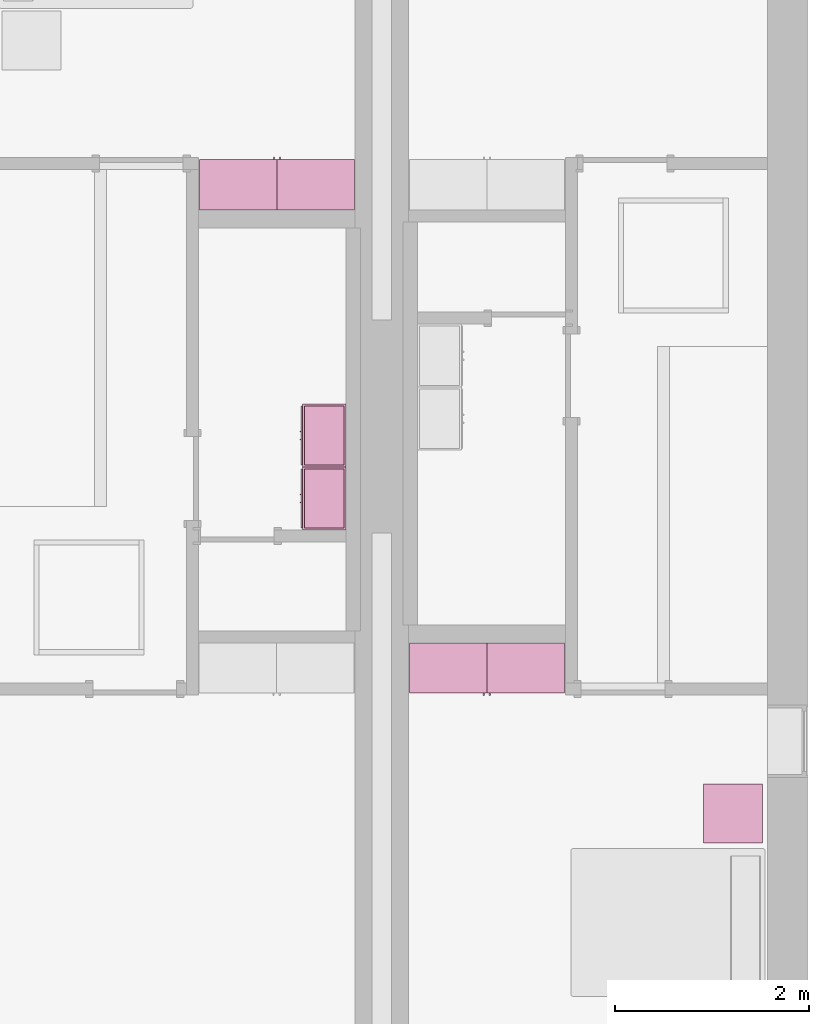
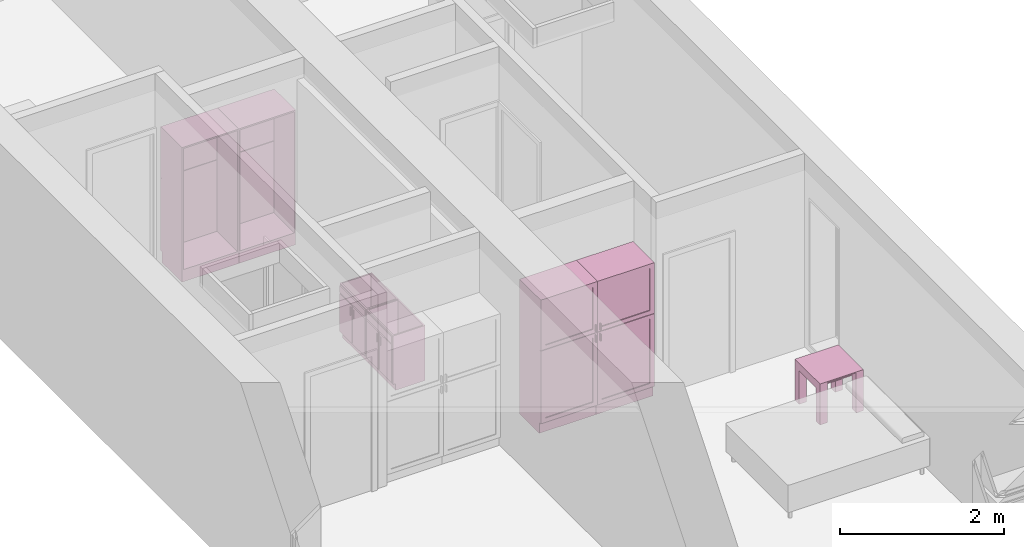
# One storey, part 8 of 10: 7 furnishings, 4 openings.
"""IFC2X3 building model written with IfcOpenShell, lengths in metres."""

from ifc_helpers import new_model, entity, si_unit, converted_unit, derived_unit, direction, frame, frame_2d, origin, origin_2d_with_axis, place, context, subcontext, project, spatial, polyline, rectangle, outline, extrude, faceted_brep, source, transform, mapped, material, material_list, type_object, type_shapes, element, save


model = new_model("IFC2X3")

# Units and contexts
model_context = context("Model", 3, precision=1e-05, world=origin(), true_north=direction((6.12303176911189e-17, 1.0)))
body_context = subcontext(model_context, "Body", "Model", "MODEL_VIEW")
ifc_project = project(units=[derived_unit("USERDEFINED", [(si_unit("LENGTHUNIT", "METRE"), -2), (si_unit("TIMEUNIT", "SECOND"), -2), (si_unit("MASSUNIT", "GRAM", prefix="KILO"), 1)]), si_unit("FREQUENCYUNIT", "HERTZ"), si_unit("LENGTHUNIT", "METRE"), si_unit("ILLUMINANCEUNIT", "LUX"), derived_unit("LINEARVELOCITYUNIT", [(si_unit("TIMEUNIT", "SECOND"), -1), (si_unit("LENGTHUNIT", "METRE"), 1)]), si_unit("POWERUNIT", "WATT"), si_unit("LUMINOUSINTENSITYUNIT", "CANDELA"), si_unit("AREAUNIT", "SQUARE_METRE"), si_unit("VOLUMEUNIT", "CUBIC_METRE"), si_unit("ELECTRICVOLTAGEUNIT", "VOLT"), si_unit("PRESSUREUNIT", "PASCAL"), converted_unit("PLANEANGLEUNIT", "DEGREE", entity("IfcRatioMeasure", 0.0174532925199433), si_unit("PLANEANGLEUNIT", "RADIAN"), dimensions=[0, 0, 0, 0, 0, 0, 0]), si_unit("THERMODYNAMICTEMPERATUREUNIT", "DEGREE_CELSIUS"), si_unit("MASSUNIT", "GRAM", prefix="KILO"), derived_unit("VOLUMETRICFLOWRATEUNIT", [(si_unit("LENGTHUNIT", "METRE"), 3), (si_unit("TIMEUNIT", "SECOND"), -1)]), si_unit("TIMEUNIT", "SECOND"), si_unit("LUMINOUSFLUXUNIT", "LUMEN"), derived_unit("USERDEFINED", [(si_unit("LUMINOUSFLUXUNIT", "LUMEN"), 1), (si_unit("TIMEUNIT", "SECOND"), 3), (si_unit("MASSUNIT", "GRAM", prefix="KILO"), -1), (si_unit("LENGTHUNIT", "METRE"), -2)]), si_unit("FORCEUNIT", "NEWTON", prefix="KILO"), si_unit("ELECTRICCURRENTUNIT", "AMPERE"), derived_unit("THERMALTRANSMITTANCEUNIT", [(si_unit("TIMEUNIT", "SECOND"), -3), (si_unit("THERMODYNAMICTEMPERATUREUNIT", "KELVIN"), -1), (si_unit("MASSUNIT", "GRAM", prefix="KILO"), 1)])], contexts=[model_context])

# Site, building, storey, space
site_placement = place(None, origin())
site = spatial("IfcSite", under=ifc_project, at=site_placement, CompositionType="ELEMENT")
building_placement = place(site_placement, origin())
building = spatial("IfcBuilding", under=site, at=building_placement, CompositionType="ELEMENT")
storey_placement = place(building_placement, frame((0.0, 0.0, 3.10000000000038)))
storey = spatial("IfcBuildingStorey", under=building, at=storey_placement, Name="Level 2", CompositionType="ELEMENT", Elevation=3.10000000000038)
space_1_placement = place(storey_placement, origin())
space_1 = spatial("IfcSpace", under=storey, at=space_1_placement, CompositionType="ELEMENT", InteriorOrExteriorSpace="INTERNAL")

# Furnishing, opening
ifc_material_1 = material(Name="Cabinets")
ifc_material_2 = material(Name="Cabinets - Handles")
ifc_material_3 = material(Name="Cabinets - Panel")
ifc_material_list_1 = material_list([ifc_material_1, ifc_material_2, ifc_material_3])
ifc_material_list_2 = material_list([ifc_material_1, ifc_material_2, ifc_material_3])
furniture_type_1 = type_object("IfcFurnitureType", Name="800 mm", AssemblyPlace="NOTDEFINED", material=ifc_material_list_2)
shared_shape_1 = source(origin(), body_context, "Body", "SweptSolid", [
    extrude(rectangle(XDim=0.00634999999999998, YDim=0.672999999999998, at=origin_2d_with_axis()), frame((0.0187377049180256, -0.504125, 0.225087499999839), z_axis=(0.0, 0.0, 1.0), x_axis=(0.0, 1.0, 0.0)), (0.0, 0.0, 1.0), 0.955960536695974),
    extrude(outline(polyline([(-0.4, -0.539892768347997), (0.4, -0.539892768347997), (0.4, 0.539892768347997), (-0.4, 0.539892768347997), (-0.4, -0.539892768347997)]), holes=[polyline([(-0.336499999999999, 0.479567768347999), (0.336499999999999, 0.479567768347999), (0.336499999999999, -0.476392768347979), (-0.336499999999999, -0.476392768347979), (-0.336499999999999, 0.479567768347999)])]), frame((0.0187377049180257, -0.52, 0.701480268347818), z_axis=(0.0, 1.0, 0.0), x_axis=(-1.0, 0.0, 0.0)), (0.0, 0.0, 1.0), 0.01905),
    extrude(rectangle(XDim=0.0254, YDim=0.0125322316306447, at=frame_2d((0.0, -3.38271077815477e-17), x_axis=(1.0, 0.0))), frame((0.387071589102702, -0.532700000000001, 1.11754803669582), z_axis=(0.0, 0.0, 1.0), x_axis=(0.0, 1.0, 0.0)), (0.0, 0.0, 1.0), 0.101599999999998),
    extrude(outline(polyline([(-0.172299999999634, 0.558941666666897), (-0.172300000000835, -1.2794708333333), (0.328649999999164, -1.27947083333363), (0.32865000000047, 0.720529166666412), (-0.156349999999529, 0.720529166666729), (-0.156349999999635, 0.558941666666897), (-0.172299999999634, 0.558941666666897)])), frame((-0.381262295081959, -0.328649999999999, 0.720529166666627), z_axis=(-1.0, 0.0, 0.0), x_axis=(0.0, 1.0, 0.0)), (0.0, 0.0, -1.0), 0.8),
    extrude(rectangle(XDim=0.0254, YDim=0.0125322316306444, at=frame_2d((0.0, 3.38271077815477e-17), x_axis=(1.0, 0.0))), frame((0.387071589102703, -0.532700000000001, 1.26994803669581), z_axis=(0.0, 0.0, 1.0), x_axis=(0.0, 1.0, 0.0)), (0.0, 0.0, 1.0), 0.1016),
    extrude(rectangle(XDim=0.00634999999999998, YDim=0.672999999999998, at=origin_2d_with_axis()), frame((0.0187377049180261, -0.504125, 1.30804803669582), z_axis=(0.0, 0.0, 1.0), x_axis=(0.0, 1.0, 0.0)), (0.0, 0.0, 1.0), 0.62845196330414),
    extrude(rectangle(XDim=0.01905, YDim=0.761899999999999, at=origin_2d_with_axis()), frame((0.018737704918025, -0.009525, 0.180637499999846), z_axis=(0.0, 0.0, 1.0), x_axis=(0.0, 1.0, 0.0)), (0.0, 0.0, 1.0), 1.80031250000011),
    extrude(outline(polyline([(-0.376138481652111, -0.4), (0.376138481652111, -0.4), (0.376138481652111, 0.4), (-0.376138481652111, 0.4), (-0.376138481652111, -0.4)]), holes=[polyline([(-0.312638481652032, -0.336499999999999), (-0.312638481652032, 0.336499999999999), (0.315813481652108, 0.336499999999999), (0.315813481652108, -0.336499999999999), (-0.312638481652032, -0.336499999999999)])]), frame((0.0187377049180258, -0.52, 1.62386151834792), z_axis=(0.0, 1.0, 0.0), x_axis=(0.0, 0.0, -1.0)), (0.0, 0.0, 1.0), 0.01905),
])
type_shapes(furniture_type_1, [shared_shape_1])
furnishing_1_placement = place(space_1_placement, frame((5.06426229508196, -11.134, 0.0)))
furnishing_1 = element("IfcFurnishingElement", 1, at=furnishing_1_placement, inside=space_1, type_object=furniture_type_1, material=ifc_material_list_1, ObjectType="800 mm", context=body_context, shape_type="MappedRepresentation", body=[
    mapped(shared_shape_1, transform((0.0, 0.0, 0.0), scale=1.0)),
])
opening_1_placement = place(storey_placement, frame((5.06426229508196, -11.134, 3.1000000000002)))
element("IfcOpeningElement", 2, at=opening_1_placement, cuts=furnishing_1, ObjectType="Opening", context=body_context, shape_type="SweptSolid", body=[
    extrude(rectangle(XDim=1.80031250000011, YDim=0.761899999999999, at=frame_2d((0.0, 0.0), x_axis=(0.0, 1.0))), frame((0.0187377049180251, 0.0, -2.01920625000048), z_axis=(0.0, -1.0, 0.0), x_axis=(-1.0, 0.0, 0.0)), (0.0, 0.0, 1.0), 0.50095),
])

ifc_material_list_3 = material_list([ifc_material_1, ifc_material_2, ifc_material_3])
ifc_material_list_4 = material_list([ifc_material_1, ifc_material_2, ifc_material_3])
furniture_type_2 = type_object("IfcFurnitureType", Name="800 mm", AssemblyPlace="NOTDEFINED", material=ifc_material_list_4)
shared_shape_2 = source(origin(), body_context, "Body", "SweptSolid", [
    extrude(outline(polyline([(-0.4, -0.539892768347997), (0.4, -0.539892768347997), (0.4, 0.539892768347997), (-0.4, 0.539892768347997), (-0.4, -0.539892768347997)]), holes=[polyline([(-0.336499999999999, 0.479567768347999), (0.336499999999999, 0.479567768347999), (0.336499999999999, -0.476392768347979), (-0.336499999999999, -0.476392768347979), (-0.336499999999999, 0.479567768347999)])]), frame((0.0187377049180257, 0.50095, 0.701480268347818), z_axis=(0.0, 1.0, 0.0), x_axis=(-1.0, 0.0, 0.0)), (0.0, 0.0, 1.0), 0.01905),
    extrude(rectangle(XDim=0.0125322316306447, YDim=0.0254, at=frame_2d((-3.38271077815477e-17, 0.0), x_axis=(1.0, 0.0))), frame((0.387071589102702, 0.532700000000001, 1.11754803669582), z_axis=(0.0, 0.0, 1.0), x_axis=(-1.0, 0.0, 0.0)), (0.0, 0.0, 1.0), 0.101599999999998),
    extrude(rectangle(XDim=0.0125322316306444, YDim=0.0254, at=frame_2d((3.38271077815477e-17, 0.0), x_axis=(1.0, 0.0))), frame((0.387071589102703, 0.532700000000001, 1.26994803669581), z_axis=(0.0, 0.0, 1.0), x_axis=(-1.0, 0.0, 0.0)), (0.0, 0.0, 1.0), 0.1016),
    extrude(outline(polyline([(-0.376138481652111, -0.4), (0.376138481652111, -0.4), (0.376138481652111, 0.4), (-0.376138481652111, 0.4), (-0.376138481652111, -0.4)]), holes=[polyline([(-0.312638481652032, -0.3365), (-0.312638481652032, 0.336499999999999), (0.315813481652108, 0.336499999999999), (0.315813481652108, -0.3365), (-0.312638481652032, -0.3365)])]), frame((0.0187377049180258, 0.50095, 1.62386151834792), z_axis=(0.0, 1.0, 0.0), x_axis=(0.0, 0.0, -1.0)), (0.0, 0.0, 1.0), 0.01905),
    extrude(rectangle(XDim=0.672999999999998, YDim=0.00634999999999998, at=frame_2d((0.0, 6.76542155630955e-17), x_axis=(1.0, 0.0))), frame((0.0187377049180261, 0.504125, 1.30804803669582), z_axis=(0.0, 0.0, 1.0), x_axis=(-1.0, 0.0, 0.0)), (0.0, 0.0, 1.0), 0.62845196330414),
    extrude(rectangle(XDim=0.672999999999998, YDim=0.00634999999999998, at=frame_2d((0.0, 6.76542155630955e-17), x_axis=(1.0, 0.0))), frame((0.0187377049180256, 0.504125, 0.225087499999839), z_axis=(0.0, 0.0, 1.0), x_axis=(-1.0, 0.0, 0.0)), (0.0, 0.0, 1.0), 0.955960536695974),
    extrude(rectangle(XDim=0.761899999999999, YDim=0.01905, at=origin_2d_with_axis()), frame((0.018737704918025, 0.009525, 0.180637499999846), z_axis=(0.0, 0.0, 1.0), x_axis=(-1.0, 0.0, 0.0)), (0.0, 0.0, 1.0), 1.80031250000011),
    extrude(outline(polyline([(-0.558941666666786, -0.172299999999999), (1.27947083333342, -0.172299999999999), (1.27947083333342, 0.32865), (-0.720529166666629, 0.328649999999999), (-0.720529166666629, -0.15635), (-0.558941666666786, -0.15635), (-0.558941666666786, -0.172299999999999)])), frame((-0.38126229508196, 0.328649999999999, 0.720529166666629), z_axis=(1.0, 0.0, 0.0), x_axis=(0.0, 0.0, 1.0)), (0.0, 0.0, 1.0), 0.8),
])
type_shapes(furniture_type_2, [shared_shape_2])
furnishing_2_placement = place(space_1_placement, frame((5.90173770491801, -11.134, 0.0), z_axis=(0.0, 0.0, 1.0), x_axis=(-1.0, 0.0, 0.0)))
furnishing_2 = element("IfcFurnishingElement", 3, at=furnishing_2_placement, inside=space_1, type_object=furniture_type_2, material=ifc_material_list_3, ObjectType="800 mm", context=body_context, shape_type="MappedRepresentation", body=[
    mapped(shared_shape_2, transform((0.0, 0.0, 0.0), scale=1.0)),
])
opening_2_placement = place(storey_placement, frame((5.90173770491801, -11.134, 3.1000000000002)))
element("IfcOpeningElement", 4, at=opening_2_placement, cuts=furnishing_2, ObjectType="Opening", context=body_context, shape_type="SweptSolid", body=[
    extrude(rectangle(XDim=1.80031250000011, YDim=0.761899999999999, at=frame_2d((5.55111512312578e-17, 0.0), x_axis=(1.0, 0.0))), frame((-0.0187377049180251, 0.0, -2.01920625000048), z_axis=(0.0, -1.0, 0.0), x_axis=(0.0, 0.0, -1.0)), (0.0, 0.0, 1.0), 0.50095),
])

# Space
space_2_placement = place(storey_placement, origin())
space_2 = spatial("IfcSpace", under=storey, at=space_2_placement, CompositionType="ELEMENT", InteriorOrExteriorSpace="INTERNAL")

# Furnishing, opening
ifc_material_list_5 = material_list([ifc_material_1, ifc_material_2, ifc_material_3])
ifc_material_list_6 = material_list([ifc_material_1, ifc_material_2, ifc_material_3])
furniture_type_3 = type_object("IfcFurnitureType", Name="800 mm", AssemblyPlace="NOTDEFINED", material=ifc_material_list_6)
shared_shape_3 = source(origin(), body_context, "Body", "SweptSolid", [
    extrude(outline(polyline([(-0.4, -0.539892768347997), (0.4, -0.539892768347997), (0.4, 0.539892768347997), (-0.4, 0.539892768347997), (-0.4, -0.539892768347997)]), holes=[polyline([(-0.336499999999999, 0.479567768347999), (0.336499999999999, 0.479567768347999), (0.336499999999999, -0.476392768347979), (-0.336499999999999, -0.476392768347979), (-0.336499999999999, 0.479567768347999)])]), frame((0.0187377049180257, -0.52, 0.701480268347818), z_axis=(0.0, 1.0, 0.0), x_axis=(-1.0, 0.0, 0.0)), (0.0, 0.0, 1.0), 0.01905),
    extrude(rectangle(XDim=0.0254, YDim=0.0125322316306444, at=frame_2d((0.0, 3.38271077815477e-17), x_axis=(1.0, 0.0))), frame((0.387071589102703, -0.532700000000001, 1.26994803669581), z_axis=(0.0, 0.0, 1.0), x_axis=(0.0, 1.0, 0.0)), (0.0, 0.0, 1.0), 0.1016),
    extrude(outline(polyline([(-0.376138481652111, -0.4), (0.376138481652111, -0.4), (0.376138481652111, 0.4), (-0.376138481652111, 0.4), (-0.376138481652111, -0.4)]), holes=[polyline([(-0.312638481652032, -0.336499999999999), (-0.312638481652032, 0.336499999999999), (0.315813481652108, 0.336499999999999), (0.315813481652108, -0.336499999999999), (-0.312638481652032, -0.336499999999999)])]), frame((0.0187377049180258, -0.52, 1.62386151834792), z_axis=(0.0, 1.0, 0.0), x_axis=(0.0, 0.0, -1.0)), (0.0, 0.0, 1.0), 0.01905),
    extrude(outline(polyline([(-0.172299999999634, 0.558941666666897), (-0.172300000000835, -1.2794708333333), (0.328649999999164, -1.27947083333363), (0.32865000000047, 0.720529166666412), (-0.156349999999529, 0.720529166666729), (-0.156349999999635, 0.558941666666897), (-0.172299999999634, 0.558941666666897)])), frame((-0.381262295081959, -0.328649999999999, 0.720529166666627), z_axis=(-1.0, 0.0, 0.0), x_axis=(0.0, 1.0, 0.0)), (0.0, 0.0, -1.0), 0.8),
    extrude(rectangle(XDim=0.0254, YDim=0.0125322316306447, at=frame_2d((0.0, -3.38271077815477e-17), x_axis=(1.0, 0.0))), frame((0.387071589102702, -0.532700000000001, 1.11754803669582), z_axis=(0.0, 0.0, 1.0), x_axis=(0.0, 1.0, 0.0)), (0.0, 0.0, 1.0), 0.101599999999998),
    extrude(rectangle(XDim=0.00634999999999998, YDim=0.672999999999998, at=origin_2d_with_axis()), frame((0.0187377049180261, -0.504125, 1.30804803669582), z_axis=(0.0, 0.0, 1.0), x_axis=(0.0, 1.0, 0.0)), (0.0, 0.0, 1.0), 0.62845196330414),
    extrude(rectangle(XDim=0.01905, YDim=0.761899999999999, at=origin_2d_with_axis()), frame((0.018737704918025, -0.009525, 0.180637499999846), z_axis=(0.0, 0.0, 1.0), x_axis=(0.0, 1.0, 0.0)), (0.0, 0.0, 1.0), 1.80031250000011),
    extrude(rectangle(XDim=0.00634999999999998, YDim=0.672999999999998, at=origin_2d_with_axis()), frame((0.0187377049180256, -0.504125, 0.225087499999839), z_axis=(0.0, 0.0, 1.0), x_axis=(0.0, 1.0, 0.0)), (0.0, 0.0, 1.0), 0.955960536695974),
])
type_shapes(furniture_type_3, [shared_shape_3])
furnishing_3_placement = place(space_2_placement, frame((3.73573770491802, -6.666, 0.0), z_axis=(0.0, 0.0, 1.0), x_axis=(-1.0, 0.0, 0.0)))
furnishing_3 = element("IfcFurnishingElement", 5, at=furnishing_3_placement, inside=space_2, type_object=furniture_type_3, material=ifc_material_list_5, ObjectType="800 mm", context=body_context, shape_type="MappedRepresentation", body=[
    mapped(shared_shape_3, transform((0.0, 0.0, 0.0), scale=1.0)),
])
opening_3_placement = place(storey_placement, frame((3.73573770491802, -6.666, 3.1000000000002)))
element("IfcOpeningElement", 6, at=opening_3_placement, cuts=furnishing_3, ObjectType="Opening", context=body_context, shape_type="SweptSolid", body=[
    extrude(rectangle(XDim=1.80031250000011, YDim=0.761899999999999, at=frame_2d((5.55111512312578e-17, 0.0), x_axis=(1.0, 0.0))), frame((-0.0187377049180267, 0.50095, -2.01920625000048), z_axis=(0.0, -1.0, 0.0), x_axis=(0.0, 0.0, -1.0)), (0.0, 0.0, 1.0), 0.50095),
])

ifc_material_list_7 = material_list([ifc_material_1, ifc_material_2, ifc_material_3])
ifc_material_list_8 = material_list([ifc_material_1, ifc_material_2, ifc_material_3])
furniture_type_4 = type_object("IfcFurnitureType", Name="800 mm", AssemblyPlace="NOTDEFINED", material=ifc_material_list_8)
shared_shape_4 = source(origin(), body_context, "Body", "SweptSolid", [
    extrude(rectangle(XDim=0.672999999999998, YDim=0.00634999999999998, at=frame_2d((0.0, 6.76542155630955e-17), x_axis=(1.0, 0.0))), frame((0.0187377049180261, 0.504125, 1.30804803669582), z_axis=(0.0, 0.0, 1.0), x_axis=(-1.0, 0.0, 0.0)), (0.0, 0.0, 1.0), 0.62845196330414),
    extrude(outline(polyline([(-0.558941666666786, -0.172299999999999), (1.27947083333342, -0.172299999999999), (1.27947083333342, 0.32865), (-0.720529166666629, 0.328649999999999), (-0.720529166666629, -0.15635), (-0.558941666666786, -0.15635), (-0.558941666666786, -0.172299999999999)])), frame((-0.38126229508196, 0.328649999999999, 0.720529166666629), z_axis=(1.0, 0.0, 0.0), x_axis=(0.0, 0.0, 1.0)), (0.0, 0.0, 1.0), 0.8),
    extrude(rectangle(XDim=0.672999999999998, YDim=0.00634999999999998, at=frame_2d((0.0, 6.76542155630955e-17), x_axis=(1.0, 0.0))), frame((0.0187377049180256, 0.504125, 0.225087499999839), z_axis=(0.0, 0.0, 1.0), x_axis=(-1.0, 0.0, 0.0)), (0.0, 0.0, 1.0), 0.955960536695974),
    extrude(rectangle(XDim=0.761899999999999, YDim=0.01905, at=origin_2d_with_axis()), frame((0.018737704918025, 0.009525, 0.180637499999846), z_axis=(0.0, 0.0, 1.0), x_axis=(-1.0, 0.0, 0.0)), (0.0, 0.0, 1.0), 1.80031250000011),
    extrude(rectangle(XDim=0.0125322316306444, YDim=0.0254, at=frame_2d((3.38271077815477e-17, 0.0), x_axis=(1.0, 0.0))), frame((0.387071589102703, 0.532700000000001, 1.26994803669581), z_axis=(0.0, 0.0, 1.0), x_axis=(-1.0, 0.0, 0.0)), (0.0, 0.0, 1.0), 0.1016),
    extrude(outline(polyline([(-0.376138481652111, -0.4), (0.376138481652111, -0.4), (0.376138481652111, 0.4), (-0.376138481652111, 0.4), (-0.376138481652111, -0.4)]), holes=[polyline([(-0.312638481652032, -0.3365), (-0.312638481652032, 0.336499999999999), (0.315813481652108, 0.336499999999999), (0.315813481652108, -0.3365), (-0.312638481652032, -0.3365)])]), frame((0.0187377049180258, 0.50095, 1.62386151834792), z_axis=(0.0, 1.0, 0.0), x_axis=(0.0, 0.0, -1.0)), (0.0, 0.0, 1.0), 0.01905),
    extrude(rectangle(XDim=0.0125322316306447, YDim=0.0254, at=frame_2d((-3.38271077815477e-17, 0.0), x_axis=(1.0, 0.0))), frame((0.387071589102702, 0.532700000000001, 1.11754803669582), z_axis=(0.0, 0.0, 1.0), x_axis=(-1.0, 0.0, 0.0)), (0.0, 0.0, 1.0), 0.101599999999998),
    extrude(outline(polyline([(-0.4, -0.539892768347997), (0.4, -0.539892768347997), (0.4, 0.539892768347997), (-0.4, 0.539892768347997), (-0.4, -0.539892768347997)]), holes=[polyline([(-0.336499999999999, 0.479567768347999), (0.336499999999999, 0.479567768347999), (0.336499999999999, -0.476392768347979), (-0.336499999999999, -0.476392768347979), (-0.336499999999999, 0.479567768347999)])]), frame((0.0187377049180257, 0.50095, 0.701480268347818), z_axis=(0.0, 1.0, 0.0), x_axis=(-1.0, 0.0, 0.0)), (0.0, 0.0, 1.0), 0.01905),
])
type_shapes(furniture_type_4, [shared_shape_4])
furnishing_4_placement = place(space_2_placement, frame((2.89826229508196, -6.66599999999999, 0.0)))
furnishing_4 = element("IfcFurnishingElement", 7, at=furnishing_4_placement, inside=space_2, type_object=furniture_type_4, material=ifc_material_list_7, ObjectType="800 mm", context=body_context, shape_type="MappedRepresentation", body=[
    mapped(shared_shape_4, transform((0.0, 0.0, 0.0), scale=1.0)),
])
opening_4_placement = place(storey_placement, frame((2.89826229508196, -6.66599999999999, 3.1000000000002)))
element("IfcOpeningElement", 8, at=opening_4_placement, cuts=furnishing_4, ObjectType="Opening", context=body_context, shape_type="SweptSolid", body=[
    extrude(rectangle(XDim=1.80031250000011, YDim=0.761899999999999, at=frame_2d((0.0, 0.0), x_axis=(0.0, 1.0))), frame((0.0187377049180203, 0.50095, -2.01920625000048), z_axis=(0.0, -1.0, 0.0), x_axis=(-1.0, 0.0, 0.0)), (0.0, 0.0, 1.0), 0.50095),
])

# Furnishing
ifc_material_4 = material(Name="Wood - Teak")
ifc_material_5 = material(Name="Glass - Clear, Grey")
ifc_material_6 = material(Name="Metal - Chrome")
ifc_material_list_9 = material_list([ifc_material_4, ifc_material_5, ifc_material_6])
ifc_material_list_10 = material_list([ifc_material_4, ifc_material_5, ifc_material_6])
furniture_type_5 = type_object("IfcFurnitureType", Name="0610 x 0610 x 0610mm", AssemblyPlace="NOTDEFINED", material=ifc_material_list_10)
shared_shape_5 = source(origin(), body_context, "Body", "SweptSolid", [
    extrude(rectangle(XDim=0.406799999999999, YDim=0.4068, at=origin_2d_with_axis()), frame((0.0182657666726316, 0.0952110778022263, 0.4957), z_axis=(0.0, 0.0, 1.0), x_axis=(-1.0, 0.0, 0.0)), (0.0, 0.0, 1.0), 0.0127),
    extrude(outline(polyline([(-0.273249999999994, -0.305), (0.324049999999978, -0.305), (0.324049999999978, 0.304999999999998), (-0.273249999999993, 0.304999999999999), (-0.273249999999993, 0.203400000000001), (0.222450000000009, 0.203400000000001), (0.222450000000009, -0.2034), (-0.273249999999994, -0.2034), (-0.273249999999994, -0.305)])), frame((0.221665766672633, 0.0952110778022354, 0.273249999999992), z_axis=(1.0, 0.0, 0.0), x_axis=(0.0, 0.0, 1.0)), (0.0, 0.0, 1.0), 0.1016),
    extrude(outline(polyline([(-0.305, -0.305000000000023), (0.305, -0.305000000000023), (0.305, 0.305000000000023), (-0.305, 0.305000000000023), (-0.305, -0.305000000000023)]), holes=[polyline([(-0.203399999999998, -0.203399999999975), (-0.203399999999998, 0.203400000000025), (0.203400000000001, 0.203400000000025), (0.203400000000001, -0.203399999999975), (-0.203399999999998, -0.203399999999975)])]), frame((0.0182657666726332, 0.0952110778022508, 0.5973), z_axis=(0.0, 0.0, 1.0), x_axis=(-1.0, 0.0, 0.0)), (0.0, 0.0, 1.0), 0.0127),
    extrude(outline(polyline([(-0.305000000000004, -0.324050000000026), (0.304999999999994, -0.324050000000026), (0.304999999999994, 0.273250000000011), (0.203400000000004, 0.273250000000011), (0.203400000000004, -0.222449999999996), (-0.203399999999994, -0.222449999999996), (-0.203399999999994, 0.273250000000011), (-0.305000000000004, 0.273250000000011), (-0.305000000000004, -0.324050000000026)])), frame((-0.286734233327367, 0.0952110778022256, 0.273250000000008), z_axis=(1.0, 0.0, 0.0), x_axis=(0.0, -1.0, 0.0)), (0.0, 0.0, 1.0), 0.1016),
    extrude(rectangle(XDim=0.406799999999999, YDim=0.4068, at=origin_2d_with_axis()), frame((0.0182657666726316, 0.0952110778022259, 0.5973), z_axis=(0.0, 0.0, 1.0), x_axis=(-1.0, 0.0, 0.0)), (0.0, 0.0, 1.0), 0.0127),
])
type_shapes(furniture_type_5, [shared_shape_5])
furnishing_5_placement = place(space_1_placement, frame((8.00473423332735, -12.9892110778022, 0.0189999999998181)))
element("IfcFurnishingElement", 9, at=furnishing_5_placement, inside=space_1, type_object=furniture_type_5, material=ifc_material_list_9, Name="M_Table-Coffee:0610 x 0610 x 0610mm", ObjectType="0610 x 0610 x 0610mm", context=body_context, shape_type="MappedRepresentation", body=[
    mapped(shared_shape_5, transform((0.0, 0.0, 0.0), scale=1.0)),
])

# Space
space_3_placement = place(storey_placement, origin())
space_3 = spatial("IfcSpace", under=storey, at=space_3_placement, CompositionType="ELEMENT", InteriorOrExteriorSpace="INTERNAL")

# Furnishings
ifc_material_list_11 = material_list([ifc_material_1, ifc_material_2])
ifc_material_list_12 = material_list([ifc_material_1, ifc_material_2])
furniture_type_6 = type_object("IfcFurnitureType", Name="650 x 450 mm", AssemblyPlace="NOTDEFINED", material=ifc_material_list_12)
shared_shape_6 = source(origin(), body_context, "Body", "Brep", [
    faceted_brep([(-0.287212295081975, -0.430950000000001, 0.0999999999999995), (-0.306262295081973, -0.45, 0.0999999999999995), (-0.306262295081973, -0.414999999999998, 0.0999999999999994), (-0.287212295081975, -0.414999999999998, 0.0999999999999995), (0.343737704918026, -0.45, 0.82), (-0.306262295081973, -0.45, 0.82), (0.343737704918026, -0.45, 0.0999999999999995), (-0.287212295081975, -0.0190499999999988, 0.82), (-0.287212295081975, -0.0190499999999988, 0.0999999999999994), (0.324687704918028, -0.0190499999999988, 0.0999999999999994), (0.324687704918028, -0.0190499999999988, 0.82), (0.324687704918028, -0.430950000000001, 0.0999999999999995), (0.324687704918028, -0.430950000000001, 0.82), (0.324687704918028, -0.414999999999998, 0.0999999999999994), (-0.306262295081973, 0.0, 0.82), (0.343737704918026, 0.0, 0.82), (0.343737704918026, 0.0, 0.0), (0.343737704918026, -0.414999999999998, 0.0), (-0.306262295081973, -0.414999999999998, 0.0), (-0.306262295081973, 0.0, 0.0), (0.343737704918026, -0.414999999999998, 0.0999999999999995), (-0.287212295081975, -0.430950000000001, 0.82)], [[[0, 1, 2, 3]], [[4, 5, 1, 6]], [[7, 8, 9, 10]], [[11, 12, 10, 9, 13]], [[3, 13, 9, 8]], [[0, 11, 6, 1]], [[14, 7, 10, 15]], [[16, 17, 18, 19]], [[18, 17, 20, 13, 3, 2]], [[21, 0, 3, 8, 7]], [[19, 14, 15, 16]], [[12, 4, 15, 10]], [[6, 11, 13, 20]], [[1, 5, 14, 19, 18, 2]], [[12, 21, 5, 4]], [[12, 11, 0, 21]], [[5, 21, 7, 14]], [[4, 6, 20, 17, 16, 15]]]),
    faceted_brep([(-0.287212295081482, -0.462699999999999, 0.800950000000086), (0.324687704918537, -0.462700000000001, 0.800950000000086), (0.324687704918537, -0.450000000000001, 0.800950000000086), (-0.287212295081482, -0.449999999999999, 0.800950000000086), (-0.287212295081482, -0.462699999999999, 0.699350000000061), (-0.287212295081482, -0.449999999999999, 0.699350000000061), (0.324687704918537, -0.462700000000001, 0.699350000000061), (0.324687704918537, -0.450000000000001, 0.699350000000061)], [[[0, 1, 2, 3]], [[4, 0, 3, 5]], [[6, 4, 5, 7]], [[1, 0, 4, 6]], [[1, 6, 7, 2]], [[2, 7, 5, 3]]]),
    faceted_brep([(0.324687704918534, -0.462700000000001, 0.680300000000043), (0.324687704918534, -0.462700000000001, 0.119049999999857), (0.324687704918534, -0.450000000000001, 0.119049999999857), (0.324687704918534, -0.450000000000001, 0.680300000000043), (0.0282627049178735, -0.4627, 0.119049999999857), (0.0282627049178735, -0.45, 0.119049999999857), (0.0282627049178735, -0.4627, 0.680300000000043), (0.0282627049178735, -0.45, 0.680300000000043)], [[[0, 1, 2, 3]], [[1, 4, 5, 2]], [[4, 6, 7, 5]], [[6, 0, 3, 7]], [[3, 2, 5, 7]], [[0, 6, 4, 1]]]),
    faceted_brep([(-0.016187295081974, -0.4754, 0.517469895035161), (-0.0288872950819744, -0.4754, 0.517469895035161), (-0.0288872950819743, -0.4627, 0.517469895035161), (-0.016187295081974, -0.4627, 0.517469895035161), (-0.016187295081974, -0.4754, 0.642200000000001), (-0.016187295081974, -0.4627, 0.642200000000001), (-0.0288872950819744, -0.4754, 0.642200000000001), (-0.0288872950819743, -0.4627, 0.642200000000001)], [[[0, 1, 2, 3]], [[4, 0, 3, 5]], [[1, 6, 7, 2]], [[4, 6, 1, 0]], [[5, 3, 2, 7]], [[6, 4, 5, 7]]]),
    faceted_brep([(0.0663627049179473, -0.4754, 0.517469895035163), (0.0536627049179471, -0.4754, 0.517469895035163), (0.0536627049179471, -0.4627, 0.517469895035163), (0.0663627049179473, -0.4627, 0.517469895035163), (0.0663627049179473, -0.4754, 0.642200000000001), (0.0663627049179473, -0.4627, 0.642200000000001), (0.0536627049179471, -0.4754, 0.642200000000001), (0.0536627049179471, -0.4627, 0.642200000000001)], [[[0, 1, 2, 3]], [[4, 0, 3, 5]], [[6, 4, 5, 7]], [[1, 6, 7, 2]], [[4, 6, 1, 0]], [[5, 3, 2, 7]]]),
    faceted_brep([(0.00921270491792386, -0.4627, 0.680300000000006), (-0.287212295081494, -0.462699999999999, 0.680300000000006), (-0.287212295081494, -0.462699999999999, 0.119049999999842), (0.00921270491792386, -0.4627, 0.119049999999842), (0.0092127049179239, -0.45, 0.680300000000006), (-0.287212295081494, -0.449999999999999, 0.680300000000006), (0.0092127049179239, -0.45, 0.119049999999842), (-0.287212295081494, -0.449999999999999, 0.119049999999842)], [[[0, 1, 2, 3]], [[1, 0, 4, 5]], [[0, 3, 6, 4]], [[3, 2, 7, 6]], [[4, 6, 7, 5]], [[2, 1, 5, 7]]]),
    faceted_brep([(0.324687704918028, -0.0190499999999988, 0.119049999999842), (-0.287212295081975, -0.0190499999999988, 0.119049999999842), (-0.287212295081975, -0.430950000000001, 0.119049999999842), (0.324687704918028, -0.430950000000001, 0.119049999999842), (-0.287212295081975, -0.0190499999999988, 0.0999999999999994), (-0.287212295081975, -0.430950000000001, 0.0999999999999994), (0.324687704918028, -0.430950000000001, 0.0999999999999994), (0.324687704918028, -0.0190499999999988, 0.0999999999999994)], [[[0, 1, 2, 3]], [[2, 1, 4, 5]], [[0, 3, 6, 7]], [[3, 2, 5, 6]], [[1, 0, 7, 4]], [[7, 6, 5, 4]]]),
])
type_shapes(furniture_type_6, [shared_shape_6])
furnishing_6_placement = place(space_3_placement, frame((4.02999999999998, -9.62631347359257, 0.0129999999998178), z_axis=(0.0, 0.0, 1.0), x_axis=(0.0, -1.0, 0.0)))
element("IfcFurnishingElement", 10, at=furnishing_6_placement, inside=space_3, type_object=furniture_type_6, material=ifc_material_list_11, Name="M_Vanity Cabinet-Double Door Sink Unit:650 x 450 mm", ObjectType="650 x 450 mm", context=body_context, shape_type="MappedRepresentation", body=[
    mapped(shared_shape_6, transform((0.0, 0.0, 0.0), scale=1.0)),
])
ifc_material_list_13 = material_list([ifc_material_1, ifc_material_2])
furnishing_7_placement = place(space_3_placement, frame((4.02999999999998, -8.97631347359257, 0.0129999999998178), z_axis=(0.0, 0.0, 1.0), x_axis=(0.0, -1.0, 0.0)))
element("IfcFurnishingElement", 11, at=furnishing_7_placement, inside=space_3, type_object=furniture_type_6, material=ifc_material_list_13, Name="M_Vanity Cabinet-Double Door Sink Unit:650 x 450 mm", ObjectType="650 x 450 mm", context=body_context, shape_type="MappedRepresentation", body=[
    mapped(shared_shape_6, transform((0.0, 0.0, 0.0), scale=1.0)),
])

save(model, "model.ifc")
